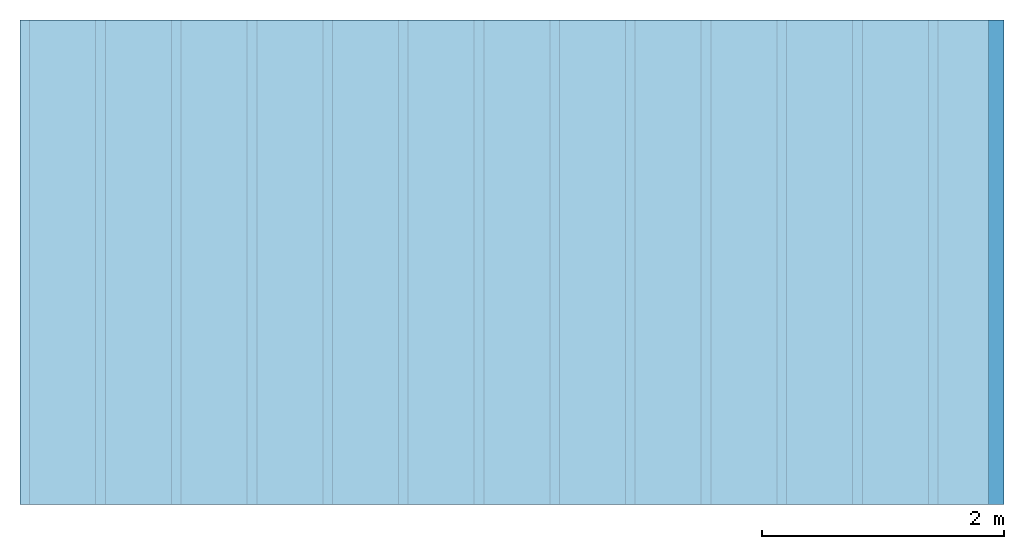
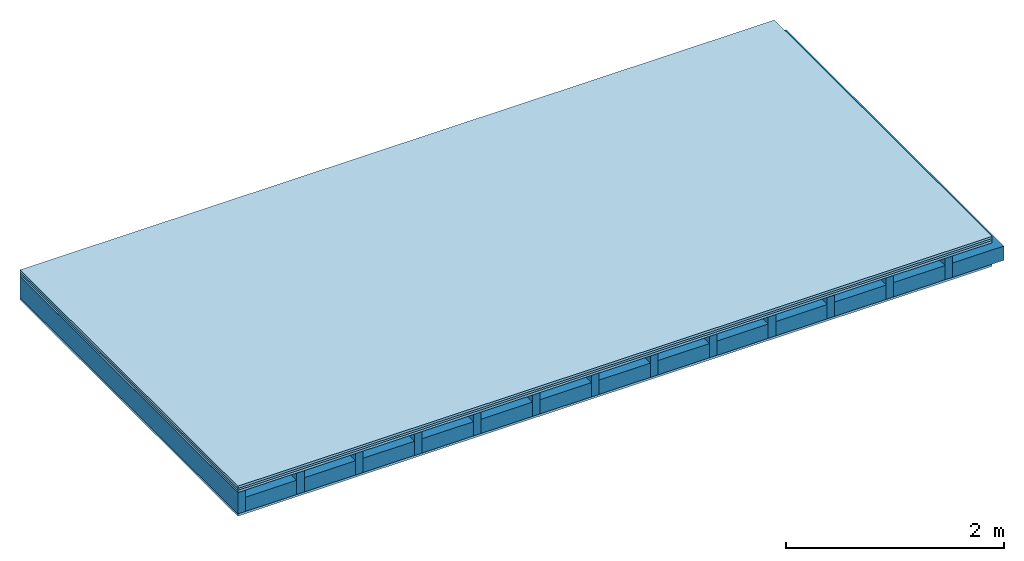
# One storey: 4 plates, 2 members, 1 element without a shape of its own.
"""IFC4 building model written with IfcOpenShell, lengths in metres."""

from ifc_helpers import new_model, si_unit, derived_unit, direction, frame, frame_2d, origin, origin_with_axes, place, context, project, spatial, rectangle, extrude, material, layer, layer_set, type_object, element, aggregate, save


model = new_model("IFC4")

# Units and contexts
plan_context = context("Plan", 3, precision=1e-05, world=origin(), true_north=direction((0.0, 1.0)))
model_context = context("Model", 3, precision=1e-05, world=origin(), true_north=direction((0.0, 1.0)))
ifc_project = project(units=[si_unit("LENGTHUNIT", "METRE"), derived_unit("SOUNDPRESSUREUNIT", [(si_unit("PRESSUREUNIT", "PASCAL", prefix="MICRO"), 0)]), si_unit("ENERGYUNIT", "JOULE", prefix="MEGA"), si_unit("MASSUNIT", "GRAM", prefix="KILO"), derived_unit("THERMALTRANSMITTANCEUNIT", [(si_unit("POWERUNIT", "WATT"), 1), (si_unit("AREAUNIT", "SQUARE_METRE"), -1), (si_unit("THERMODYNAMICTEMPERATUREUNIT", "KELVIN"), -1)]), derived_unit("AREADENSITYUNIT", [(si_unit("MASSUNIT", "GRAM", prefix="KILO"), 1), (si_unit("AREAUNIT", "SQUARE_METRE"), -1)]), derived_unit("USERDEFINED", [(si_unit("ENERGYUNIT", "JOULE", prefix="MEGA"), 1), (si_unit("AREAUNIT", "SQUARE_METRE"), -1)])], contexts=[plan_context, model_context])

# Site, building, storey
site = spatial("IfcSite", under=ifc_project)
building_placement = place(None, origin())
building = spatial("IfcBuilding", under=site, at=building_placement)
storey_placement = place(building_placement, origin())
storey = spatial("IfcBuildingStorey", under=building, at=storey_placement)

# Slab, members, plates
ifc_material_1 = material(Name="Floor heating system Therm38 longitudinal", Category="03.007")
ifc_layer_1 = layer(ifc_material_1, 0.025, Name="On-material")
ifc_material_2 = material(Category="10.009")
ifc_layer_2 = layer(ifc_material_2, 0.022, Name="Impact sound insulation")
ifc_material_3 = material(Category="07.001")
ifc_layer_3 = layer(ifc_material_3, 0.025, Name="Sub-floor")
ifc_material_4 = material(Name="Rigid, of the art")
ifc_layer_4 = layer(ifc_material_4, 0.0, Name="Bond")
ifc_layer_5 = layer(None, 0.24, Name="Supporting structure")
ifc_layer_6 = layer(ifc_material_4, 0.0, Name="Bond")
ifc_layer_7 = layer(ifc_material_3, 0.025, Name="Lower layer 1")
ifc_layer_set = layer_set([ifc_layer_1, ifc_layer_2, ifc_layer_3, ifc_layer_4, ifc_layer_5, ifc_layer_6, ifc_layer_7])
slab_type = type_object("IfcSlabType", Name="A0453", PredefinedType="NOTDEFINED", material=ifc_layer_set)
slab_placement = place(None, frame((0.0, 0.0, 0.0), z_axis=(0.0, 0.0, -1.0), x_axis=(1.0, 0.0, 0.0)))
slab = element("IfcSlab", 1, at=slab_placement, inside=storey, type_object=slab_type, material=ifc_layer_set, Name="Slab #1")
ifc_material_5 = material()
member_1_placement = place(slab_placement, origin())
member_1 = element("IfcMember", 2, at=member_1_placement, material=ifc_material_5, Name="Supporting structure", context=plan_context, shape_type="SweptSolid", body=[
    extrude(rectangle(XDim=0.08, YDim=0.24, at=frame_2d((0.04, 0.12), x_axis=(1.0, 0.0))), frame((0.0, 4.0, 0.072), z_axis=(0.0, -1.0, 0.0), x_axis=(1.0, 0.0, 0.0)), (0.0, 0.0, 1.0), 4.0),
    extrude(rectangle(XDim=0.08, YDim=0.24, at=frame_2d((0.04, 0.12), x_axis=(1.0, 0.0))), frame((0.625, 4.0, 0.072), z_axis=(0.0, -1.0, 0.0), x_axis=(1.0, 0.0, 0.0)), (0.0, 0.0, 1.0), 4.0),
    extrude(rectangle(XDim=0.08, YDim=0.24, at=frame_2d((0.04, 0.12), x_axis=(1.0, 0.0))), frame((1.25, 4.0, 0.072), z_axis=(0.0, -1.0, 0.0), x_axis=(1.0, 0.0, 0.0)), (0.0, 0.0, 1.0), 4.0),
    extrude(rectangle(XDim=0.08, YDim=0.24, at=frame_2d((0.04, 0.12), x_axis=(1.0, 0.0))), frame((1.875, 4.0, 0.072), z_axis=(0.0, -1.0, 0.0), x_axis=(1.0, 0.0, 0.0)), (0.0, 0.0, 1.0), 4.0),
    extrude(rectangle(XDim=0.08, YDim=0.24, at=frame_2d((0.04, 0.12), x_axis=(1.0, 0.0))), frame((2.5, 4.0, 0.072), z_axis=(0.0, -1.0, 0.0), x_axis=(1.0, 0.0, 0.0)), (0.0, 0.0, 1.0), 4.0),
    extrude(rectangle(XDim=0.08, YDim=0.24, at=frame_2d((0.04, 0.12), x_axis=(1.0, 0.0))), frame((3.125, 4.0, 0.072), z_axis=(0.0, -1.0, 0.0), x_axis=(1.0, 0.0, 0.0)), (0.0, 0.0, 1.0), 4.0),
    extrude(rectangle(XDim=0.08, YDim=0.24, at=frame_2d((0.04, 0.12), x_axis=(1.0, 0.0))), frame((3.75, 4.0, 0.072), z_axis=(0.0, -1.0, 0.0), x_axis=(1.0, 0.0, 0.0)), (0.0, 0.0, 1.0), 4.0),
    extrude(rectangle(XDim=0.08, YDim=0.24, at=frame_2d((0.04, 0.12), x_axis=(1.0, 0.0))), frame((4.375, 4.0, 0.072), z_axis=(0.0, -1.0, 0.0), x_axis=(1.0, 0.0, 0.0)), (0.0, 0.0, 1.0), 4.0),
    extrude(rectangle(XDim=0.08, YDim=0.24, at=frame_2d((0.04, 0.12), x_axis=(1.0, 0.0))), frame((5.0, 4.0, 0.072), z_axis=(0.0, -1.0, 0.0), x_axis=(1.0, 0.0, 0.0)), (0.0, 0.0, 1.0), 4.0),
    extrude(rectangle(XDim=0.08, YDim=0.24, at=frame_2d((0.04, 0.12), x_axis=(1.0, 0.0))), frame((5.625, 4.0, 0.072), z_axis=(0.0, -1.0, 0.0), x_axis=(1.0, 0.0, 0.0)), (0.0, 0.0, 1.0), 4.0),
    extrude(rectangle(XDim=0.08, YDim=0.24, at=frame_2d((0.04, 0.12), x_axis=(1.0, 0.0))), frame((6.25, 4.0, 0.072), z_axis=(0.0, -1.0, 0.0), x_axis=(1.0, 0.0, 0.0)), (0.0, 0.0, 1.0), 4.0),
    extrude(rectangle(XDim=0.08, YDim=0.24, at=frame_2d((0.04, 0.12), x_axis=(1.0, 0.0))), frame((6.875, 4.0, 0.072), z_axis=(0.0, -1.0, 0.0), x_axis=(1.0, 0.0, 0.0)), (0.0, 0.0, 1.0), 4.0),
    extrude(rectangle(XDim=0.08, YDim=0.24, at=frame_2d((0.04, 0.12), x_axis=(1.0, 0.0))), frame((7.5, 4.0, 0.072), z_axis=(0.0, -1.0, 0.0), x_axis=(1.0, 0.0, 0.0)), (0.0, 0.0, 1.0), 4.0),
])
ifc_material_6 = material()
member_2_placement = place(slab_placement, origin())
member_2 = element("IfcMember", 3, at=member_2_placement, material=ifc_material_6, Name="in supporting structure", context=plan_context, shape_type="SweptSolid", body=[
    extrude(rectangle(XDim=0.545, YDim=0.16, at=frame_2d((0.2725, 0.08), x_axis=(1.0, 0.0))), frame((0.08, 4.0, 0.152), z_axis=(0.0, -1.0, 0.0), x_axis=(1.0, 0.0, 0.0)), (0.0, 0.0, 1.0), 4.0),
    extrude(rectangle(XDim=0.545, YDim=0.16, at=frame_2d((0.2725, 0.08), x_axis=(1.0, 0.0))), frame((0.705, 4.0, 0.152), z_axis=(0.0, -1.0, 0.0), x_axis=(1.0, 0.0, 0.0)), (0.0, 0.0, 1.0), 4.0),
    extrude(rectangle(XDim=0.545, YDim=0.16, at=frame_2d((0.2725, 0.08), x_axis=(1.0, 0.0))), frame((1.33, 4.0, 0.152), z_axis=(0.0, -1.0, 0.0), x_axis=(1.0, 0.0, 0.0)), (0.0, 0.0, 1.0), 4.0),
    extrude(rectangle(XDim=0.545, YDim=0.16, at=frame_2d((0.2725, 0.08), x_axis=(1.0, 0.0))), frame((1.955, 4.0, 0.152), z_axis=(0.0, -1.0, 0.0), x_axis=(1.0, 0.0, 0.0)), (0.0, 0.0, 1.0), 4.0),
    extrude(rectangle(XDim=0.545, YDim=0.16, at=frame_2d((0.2725, 0.08), x_axis=(1.0, 0.0))), frame((2.58, 4.0, 0.152), z_axis=(0.0, -1.0, 0.0), x_axis=(1.0, 0.0, 0.0)), (0.0, 0.0, 1.0), 4.0),
    extrude(rectangle(XDim=0.545, YDim=0.16, at=frame_2d((0.2725, 0.08), x_axis=(1.0, 0.0))), frame((3.205, 4.0, 0.152), z_axis=(0.0, -1.0, 0.0), x_axis=(1.0, 0.0, 0.0)), (0.0, 0.0, 1.0), 4.0),
    extrude(rectangle(XDim=0.545, YDim=0.16, at=frame_2d((0.2725, 0.08), x_axis=(1.0, 0.0))), frame((3.83, 4.0, 0.152), z_axis=(0.0, -1.0, 0.0), x_axis=(1.0, 0.0, 0.0)), (0.0, 0.0, 1.0), 4.0),
    extrude(rectangle(XDim=0.545, YDim=0.16, at=frame_2d((0.2725, 0.08), x_axis=(1.0, 0.0))), frame((4.455, 4.0, 0.152), z_axis=(0.0, -1.0, 0.0), x_axis=(1.0, 0.0, 0.0)), (0.0, 0.0, 1.0), 4.0),
    extrude(rectangle(XDim=0.545, YDim=0.16, at=frame_2d((0.2725, 0.08), x_axis=(1.0, 0.0))), frame((5.08, 4.0, 0.152), z_axis=(0.0, -1.0, 0.0), x_axis=(1.0, 0.0, 0.0)), (0.0, 0.0, 1.0), 4.0),
    extrude(rectangle(XDim=0.545, YDim=0.16, at=frame_2d((0.2725, 0.08), x_axis=(1.0, 0.0))), frame((5.705, 4.0, 0.152), z_axis=(0.0, -1.0, 0.0), x_axis=(1.0, 0.0, 0.0)), (0.0, 0.0, 1.0), 4.0),
    extrude(rectangle(XDim=0.545, YDim=0.16, at=frame_2d((0.2725, 0.08), x_axis=(1.0, 0.0))), frame((6.33, 4.0, 0.152), z_axis=(0.0, -1.0, 0.0), x_axis=(1.0, 0.0, 0.0)), (0.0, 0.0, 1.0), 4.0),
    extrude(rectangle(XDim=0.545, YDim=0.16, at=frame_2d((0.2725, 0.08), x_axis=(1.0, 0.0))), frame((6.955, 4.0, 0.152), z_axis=(0.0, -1.0, 0.0), x_axis=(1.0, 0.0, 0.0)), (0.0, 0.0, 1.0), 4.0),
    extrude(rectangle(XDim=0.545, YDim=0.16, at=frame_2d((0.2725, 0.08), x_axis=(1.0, 0.0))), frame((7.58, 4.0, 0.152), z_axis=(0.0, -1.0, 0.0), x_axis=(1.0, 0.0, 0.0)), (0.0, 0.0, 1.0), 4.0),
])
plate_1_placement = place(slab_placement, origin())
plate_1 = element("IfcPlate", 4, at=plate_1_placement, material=ifc_material_1, Name="On-material", context=plan_context, shape_type="SweptSolid", body=[
    extrude(rectangle(XDim=8.0, YDim=4.0, at=frame_2d((4.0, 2.0), x_axis=(1.0, 0.0))), origin_with_axes(), (0.0, 0.0, 1.0), 0.025),
])
plate_2_placement = place(slab_placement, origin())
plate_2 = element("IfcPlate", 5, at=plate_2_placement, material=ifc_material_2, Name="Impact sound insulation", context=plan_context, shape_type="SweptSolid", body=[
    extrude(rectangle(XDim=8.0, YDim=4.0, at=frame_2d((4.0, 2.0), x_axis=(1.0, 0.0))), frame((0.0, 0.0, 0.025), z_axis=(0.0, 0.0, 1.0), x_axis=(1.0, 0.0, 0.0)), (0.0, 0.0, 1.0), 0.022),
])
plate_3_placement = place(slab_placement, origin())
plate_3 = element("IfcPlate", 6, at=plate_3_placement, material=ifc_material_3, Name="Sub-floor", context=plan_context, shape_type="SweptSolid", body=[
    extrude(rectangle(XDim=8.0, YDim=4.0, at=frame_2d((4.0, 2.0), x_axis=(1.0, 0.0))), frame((0.0, 0.0, 0.047), z_axis=(0.0, 0.0, 1.0), x_axis=(1.0, 0.0, 0.0)), (0.0, 0.0, 1.0), 0.025),
])
plate_4_placement = place(slab_placement, origin())
plate_4 = element("IfcPlate", 7, at=plate_4_placement, material=ifc_material_3, Name="Lower layer 1", context=plan_context, shape_type="SweptSolid", body=[
    extrude(rectangle(XDim=8.0, YDim=4.0, at=frame_2d((4.0, 2.0), x_axis=(1.0, 0.0))), frame((0.0, 0.0, 0.312), z_axis=(0.0, 0.0, 1.0), x_axis=(1.0, 0.0, 0.0)), (0.0, 0.0, 1.0), 0.025),
])
aggregate(slab, [plate_1, plate_2, plate_3, member_1, member_2, plate_4])

save(model, "model.ifc")
